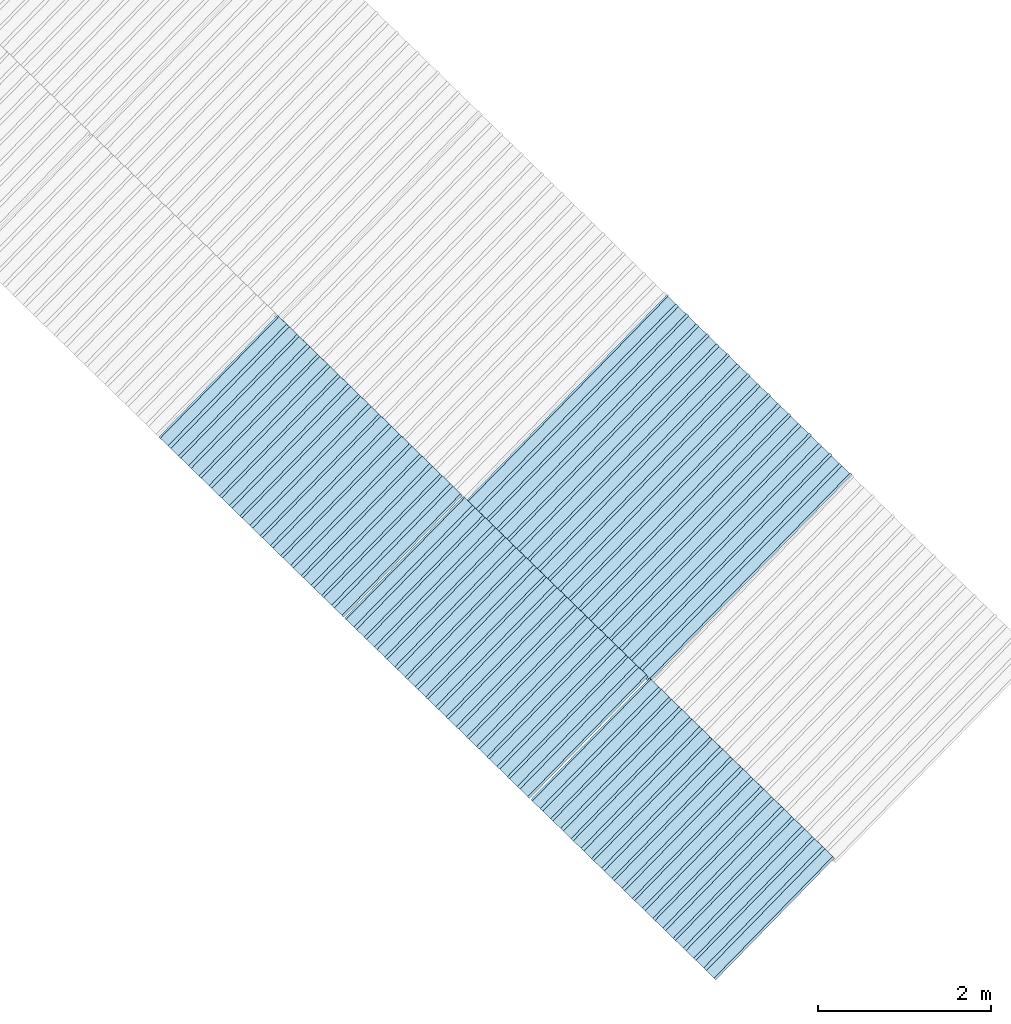
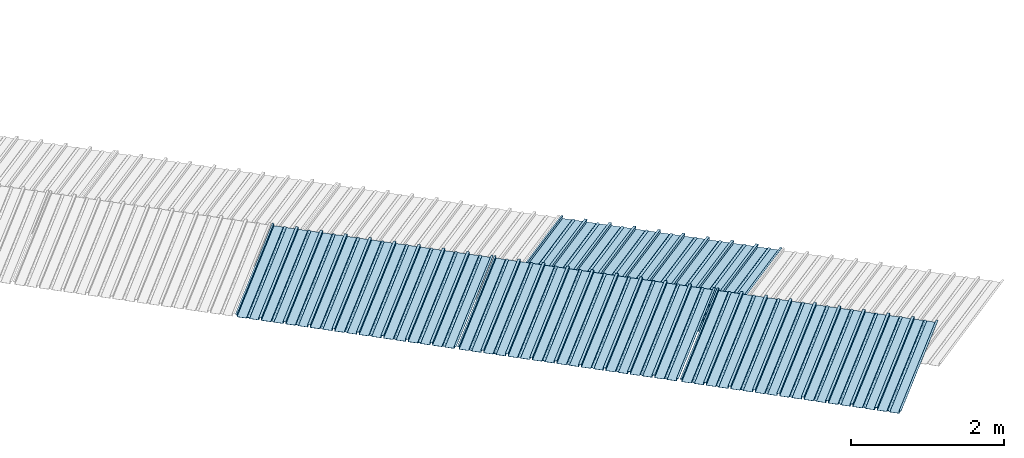
# One storey, part 3 of 8: 4 plates, 2 elements without a shape of their own.
"""IFC4 building model written with IfcOpenShell, lengths in metres."""

from ifc_helpers import new_model, entity, si_unit, converted_unit, direction, frame, origin, place, context, subcontext, project, spatial, line, arc, indexed_curve, outline, extrude, source, transform, mapped, material, type_object, type_shapes, element, aggregate, save


model = new_model("IFC4")

# Units and contexts
model_context = context("Model", 3, precision=1e-05, world=origin(), true_north=direction((6.123233995736766e-17, 1.0)))
body_context = subcontext(model_context, "Body", "Model", "MODEL_VIEW")
ifc_project = project(units=[si_unit("LENGTHUNIT", "METRE"), si_unit("AREAUNIT", "SQUARE_METRE"), si_unit("VOLUMEUNIT", "CUBIC_METRE"), converted_unit("PLANEANGLEUNIT", "DEGREE", entity("IfcPlaneAngleMeasure", 0.017453292519943278), si_unit("PLANEANGLEUNIT", "RADIAN"), dimensions=[0, 0, 0, 0, 0, 0, 0])], contexts=[model_context])

# Site, building, storey
site_placement = place(None, frame((0.0, 0.0, 0.0), z_axis=(0.0, 0.0, 1.0), x_axis=(0.7160934825303189, -0.6980043870045516, 0.0)))
site = spatial("IfcSite", under=ifc_project, at=site_placement, CompositionType="ELEMENT")
building_placement = place(site_placement, origin())
building = spatial("IfcBuilding", under=site, at=building_placement, CompositionType="ELEMENT")
storey_placement = place(building_placement, frame((0.0, 0.0, -1.24)))
storey = spatial("IfcBuildingStorey", under=building, at=storey_placement, Name="Livello 5", CompositionType="ELEMENT", Elevation=-1.24)

# Roof, plates
curtain_wall_type = type_object("IfcCurtainWallType", Name="Vetrata Copertura 2", PredefinedType="NOTDEFINED")
roof_1_placement = place(storey_placement, frame((0.0, 0.0, 1.24)))
roof_1 = element("IfcRoof", 1, at=roof_1_placement, inside=storey, type_object=curtain_wall_type, Name="Vetrata Copertura 2", ObjectType="Vetrata Copertura 2", PredefinedType="SHED_ROOF")
ifc_material = material(Name="Default")
plate_type_1 = type_object("IfcPlateType", Name="Pannello copertura:Pannello copertura", PredefinedType="CURTAIN_PANEL", material=ifc_material)
shared_shape_1 = source(origin(), body_context, "Body", "SweptSolid", [
    extrude(outline(indexed_curve([(1.339910560042256, -0.015785714285718594), (1.4699105600422562, -0.015785714285719003), (1.4699105600422562, 0.024214285714281004), (1.494919197675959, 0.02421428571428092), (1.494919197675959, 0.027214285714280917), (1.466910560042256, 0.027214285714281014), (1.466910560042256, -0.012785714285718995), (1.3417510978483753, -0.012785714285718492), (1.3199105600422556, 4.9134324369942785e-05), (1.2980700222361363, -0.012785714285718328), (1.1729105600422558, -0.01278571428571804), (1.1729105600422558, 0.02721428571428197), (1.136910560042256, 0.027214285714282097), (1.136910560042256, -0.012785714285717937), (1.0117510978483748, -0.01278571428571754), (0.9899105600422554, 4.913432437100935e-05), (0.968070022236136, -0.01278571428571726), (0.8429105600422558, -0.012785714285716971), (0.842910560042256, 0.027214285714283023), (0.8069105600422554, 0.027214285714283144), (0.8069105600422554, -0.01278571428571687), (0.6817510978483748, -0.012785714285716475), (0.6599105600422555, 4.9134324372075926e-05), (0.6380700222361361, -0.012785714285716196), (0.5129105600422553, -0.012785714285715915), (0.5129105600422554, 0.027214285714284105), (0.47691056004225557, 0.027214285714284227), (0.47691056004225557, -0.012785714285715804), (0.3517510978483749, -0.012785714285715427), (0.32991056004225544, 4.9134324373142496e-05), (0.3080700222361361, -0.012785714285715127), (0.18291056004225528, -0.012785714285714848), (0.18291056004225553, 0.027214285714285157), (0.1469105600422553, 0.02721428571428528), (0.14691056004225533, -0.012785714285714738), (0.021751097848374697, -0.01278571428571434), (-8.943995774469983e-05, 4.913432437420907e-05), (-0.021929977763864118, -0.01278571428571406), (-0.1470894399577447, -0.012785714285713783), (-0.14708943995774473, 0.02721428571428624), (-0.18308943995774493, 0.027214285714286364), (-0.1830894399577449, -0.012785714285713672), (-0.30824890215162537, -0.012785714285713215), (-0.33008943995774487, 4.9134324375275644e-05), (-0.3519299777638641, -0.012785714285712995), (-0.47708943995774494, -0.012785714285712714), (-0.4770894399577447, 0.02721428571428729), (-0.5130894399577449, 0.02721428571428741), (-0.5130894399577449, -0.012785714285712603), (-0.6382489021516256, -0.012785714285712207), (-0.6600894399577448, 4.9134324376342214e-05), (-0.6819299777638644, -0.012785714285711926), (-0.8070894399577453, -0.012785714285711647), (-0.807089439957745, 0.027214285714288373), (-0.843089439957745, 0.027214285714288494), (-0.8430894399577447, -0.012785714285711538), (-0.968248902151626, -0.012785714285711083), (-0.9900894399577453, 4.9134324377408785e-05), (-1.0119299777638646, -0.012785714285710861), (-1.1370894399577456, -0.012785714285710582), (-1.1370894399577451, 0.02721428571428942), (-1.1730894399577452, 0.027214285714289545), (-1.1730894399577454, -0.012785714285710473), (-1.2982489021516257, -0.012785714285710093), (-1.3200894399577452, 4.9134324378475355e-05), (-1.3419299777638647, -0.012785714285709794), (-1.4670894399577457, -0.012785714285709513), (-1.4670894399577454, 0.027214285714290503), (-1.490089439957745, 0.027214285714290586), (-1.490089439957745, 0.024214285714290556), (-1.4700894399577447, 0.02421428571429049), (-1.4700894399577449, -0.015785714285709514), (-1.3400894399577452, -0.015785714285709924), (-1.3200894399577452, -0.0029508656756215236), (-1.3000894399577452, -0.015785714285710063), (-1.170089439957745, -0.015785714285710472), (-1.1700894399577453, 0.024214285714289543), (-1.140089439957745, 0.02421428571428944), (-1.1400894399577455, -0.015785714285710583), (-1.0100894399577454, -0.015785714285710992), (-0.9900894399577453, -0.00295086567562259), (-0.9700894399577453, -0.015785714285711128), (-0.8400894399577448, -0.01578571428571154), (-0.8400894399577451, 0.024214285714288453), (-0.8100894399577452, 0.024214285714288356), (-0.8100894399577452, -0.015785714285711648), (-0.6800894399577451, -0.015785714285712012), (-0.6600894399577448, -0.0029508656756236573), (-0.6400894399577448, -0.015785714285712196), (-0.5100894399577451, -0.015785714285712606), (-0.5100894399577451, 0.024214285714287406), (-0.4800894399577449, 0.024214285714287305), (-0.4800894399577449, -0.015785714285712713), (-0.350089439957745, -0.01578571428571316), (-0.33008943995774487, -0.0029508656756247237), (-0.31008943995774485, -0.01578571428571326), (-0.1800894399577448, -0.015785714285713674), (-0.1800894399577448, 0.024214285714286323), (-0.1500894399577446, 0.02421428571428622), (-0.15008943995774485, -0.015785714285713782), (-0.020089439957744877, -0.015785714285714264), (-8.943995774473269e-05, -0.00295086567562579), (0.01991056004225521, -0.015785714285714323), (0.14991056004225545, -0.01578571428571474), (0.14991056004225542, 0.024214285714285272), (0.17991056004225567, 0.02421428571428517), (0.1799105600422554, -0.01578571428571485), (0.30991056004225526, -0.01578571428571532), (0.32991056004225544, -0.0029508656756268565), (0.3499105600422554, -0.015785714285715395), (0.47991056004225535, -0.015785714285715804), (0.47991056004225535, 0.02421428571428419), (0.5099105600422553, 0.02421428571428409), (0.5099105600422552, -0.015785714285715916), (0.6399105600422554, -0.015785714285716325), (0.6599105600422555, -0.002950865675627923), (0.6799105600422555, -0.01578571428571646), (0.8099105600422557, -0.015785714285716873), (0.8099105600422557, 0.02421428571428314), (0.8399105600422555, 0.02421428571428304), (0.8399105600422554, -0.015785714285716974), (0.9699105600422554, -0.015785714285717393), (0.9899105600422554, -0.0029508656756289894), (1.0099105600422555, -0.01578571428571753), (1.1399105600422557, -0.015785714285717938), (1.1399105600422557, 0.024214285714282077), (1.169910560042256, 0.024214285714281972), (1.1699105600422557, -0.01578571428571804), (1.2999105600422558, -0.01578571428571846), (1.3199105600422558, -0.0029508656756300567)], segments=[line(1, 2, 3, 4, 5, 6, 7, 8), arc(8, 9, 10), line(10, 11, 12, 13, 14, 15), arc(15, 16, 17), line(17, 18, 19, 20, 21, 22), arc(22, 23, 24), line(24, 25, 26, 27, 28, 29), arc(29, 30, 31), line(31, 32, 33, 34, 35, 36), arc(36, 37, 38), line(38, 39, 40, 41, 42, 43), arc(43, 44, 45), line(45, 46, 47, 48, 49, 50), arc(50, 51, 52), line(52, 53, 54, 55, 56, 57), arc(57, 58, 59), line(59, 60, 61, 62, 63, 64), arc(64, 65, 66), line(66, 67, 68, 69, 70, 71, 72, 73), arc(73, 74, 75), line(75, 76, 77, 78, 79, 80), arc(80, 81, 82), line(82, 83, 84, 85, 86, 87), arc(87, 88, 89), line(89, 90, 91, 92, 93, 94), arc(94, 95, 96), line(96, 97, 98, 99, 100, 101), arc(101, 102, 103), line(103, 104, 105, 106, 107, 108), arc(108, 109, 110), line(110, 111, 112, 113, 114, 115), arc(115, 116, 117), line(117, 118, 119, 120, 121, 122), arc(122, 123, 124), line(124, 125, 126, 127, 128, 129), arc(129, 130, 1)], self_intersect=False)), frame((8.080232403624576e-05, -0.015785714285719014, 0.0), z_axis=(0.0, 0.0, -1.0), x_axis=(1.0, 0.0, 0.0)), (0.0, 0.0, -1.0), 1.9691142879617602),
])
type_shapes(plate_type_1, [shared_shape_1])
plate_1_placement = place(roof_1_placement, frame((0.7679036127094641, -6.922854376535778, -1.0800000000000003), z_axis=(0.0, 0.9980594686585702, 0.0622679453729828), x_axis=(1.0, 0.0, 0.0)))
plate_1 = element("IfcPlate", 2, at=plate_1_placement, type_object=plate_type_1, material=ifc_material, Name="Pannello copertura:Pannello copertura", ObjectType="Pannello copertura:Pannello copertura", PredefinedType="CURTAIN_PANEL", context=body_context, shape_type="MappedRepresentation", body=[
    mapped(shared_shape_1, transform((0.0, 0.0, 0.0), scale=1.0)),
])
plate_2_placement = place(roof_1_placement, frame((3.7679082367906167, -6.922854376535778, -1.0800000000000003), z_axis=(0.0, 0.9980594686585702, 0.0622679453729828), x_axis=(1.0, 0.0, 0.0)))
plate_2 = element("IfcPlate", 3, at=plate_2_placement, type_object=plate_type_1, material=ifc_material, Name="Pannello copertura:Pannello copertura", ObjectType="Pannello copertura:Pannello copertura", PredefinedType="CURTAIN_PANEL", context=body_context, shape_type="MappedRepresentation", body=[
    mapped(shared_shape_1, transform((0.0, 0.0, 0.0), scale=1.0)),
])
plate_type_2 = type_object("IfcPlateType", Name="Pannello copertura:Pannello copertura", PredefinedType="CURTAIN_PANEL", material=ifc_material)
shared_shape_2 = source(origin(), body_context, "Body", "SweptSolid", [
    extrude(outline(indexed_curve([(1.339910560042256, -0.015785714285718594), (1.4699105600422562, -0.015785714285719003), (1.4699105600422562, 0.024214285714281004), (1.494919197675959, 0.02421428571428092), (1.494919197675959, 0.027214285714280917), (1.466910560042256, 0.027214285714281014), (1.466910560042256, -0.012785714285718995), (1.3417510978483753, -0.012785714285718492), (1.3199105600422556, 4.9134324369942785e-05), (1.2980700222361363, -0.012785714285718328), (1.1729105600422558, -0.01278571428571804), (1.1729105600422558, 0.02721428571428197), (1.136910560042256, 0.027214285714282097), (1.136910560042256, -0.012785714285717937), (1.0117510978483748, -0.01278571428571754), (0.9899105600422554, 4.913432437100935e-05), (0.968070022236136, -0.01278571428571726), (0.8429105600422558, -0.012785714285716971), (0.842910560042256, 0.027214285714283023), (0.8069105600422554, 0.027214285714283144), (0.8069105600422554, -0.01278571428571687), (0.6817510978483748, -0.012785714285716475), (0.6599105600422555, 4.9134324372075926e-05), (0.6380700222361361, -0.012785714285716196), (0.5129105600422553, -0.012785714285715915), (0.5129105600422554, 0.027214285714284105), (0.47691056004225557, 0.027214285714284227), (0.47691056004225557, -0.012785714285715804), (0.3517510978483749, -0.012785714285715427), (0.32991056004225544, 4.9134324373142496e-05), (0.3080700222361361, -0.012785714285715127), (0.18291056004225528, -0.012785714285714848), (0.18291056004225553, 0.027214285714285157), (0.1469105600422553, 0.02721428571428528), (0.14691056004225533, -0.012785714285714738), (0.021751097848374697, -0.01278571428571434), (-8.943995774469983e-05, 4.913432437420907e-05), (-0.021929977763864118, -0.01278571428571406), (-0.1470894399577447, -0.012785714285713783), (-0.14708943995774473, 0.02721428571428624), (-0.18308943995774493, 0.027214285714286364), (-0.1830894399577449, -0.012785714285713672), (-0.30824890215162537, -0.012785714285713215), (-0.33008943995774487, 4.9134324375275644e-05), (-0.3519299777638641, -0.012785714285712995), (-0.47708943995774494, -0.012785714285712714), (-0.4770894399577447, 0.02721428571428729), (-0.5130894399577449, 0.02721428571428741), (-0.5130894399577449, -0.012785714285712603), (-0.6382489021516256, -0.012785714285712207), (-0.6600894399577448, 4.9134324376342214e-05), (-0.6819299777638644, -0.012785714285711926), (-0.8070894399577453, -0.012785714285711647), (-0.807089439957745, 0.027214285714288373), (-0.843089439957745, 0.027214285714288494), (-0.8430894399577447, -0.012785714285711538), (-0.968248902151626, -0.012785714285711083), (-0.9900894399577453, 4.9134324377408785e-05), (-1.0119299777638646, -0.012785714285710861), (-1.1370894399577456, -0.012785714285710582), (-1.1370894399577451, 0.02721428571428942), (-1.1730894399577452, 0.027214285714289545), (-1.1730894399577454, -0.012785714285710473), (-1.2982489021516257, -0.012785714285710093), (-1.3200894399577452, 4.9134324378475355e-05), (-1.3419299777638647, -0.012785714285709794), (-1.4670894399577457, -0.012785714285709513), (-1.4670894399577454, 0.027214285714290503), (-1.490089439957745, 0.027214285714290586), (-1.490089439957745, 0.024214285714290556), (-1.4700894399577447, 0.02421428571429049), (-1.4700894399577449, -0.015785714285709514), (-1.3400894399577452, -0.015785714285709924), (-1.3200894399577452, -0.0029508656756215236), (-1.3000894399577452, -0.015785714285710063), (-1.170089439957745, -0.015785714285710472), (-1.1700894399577453, 0.024214285714289543), (-1.140089439957745, 0.02421428571428944), (-1.1400894399577455, -0.015785714285710583), (-1.0100894399577454, -0.015785714285710992), (-0.9900894399577453, -0.00295086567562259), (-0.9700894399577453, -0.015785714285711128), (-0.8400894399577448, -0.01578571428571154), (-0.8400894399577451, 0.024214285714288453), (-0.8100894399577452, 0.024214285714288356), (-0.8100894399577452, -0.015785714285711648), (-0.6800894399577451, -0.015785714285712012), (-0.6600894399577448, -0.0029508656756236573), (-0.6400894399577448, -0.015785714285712196), (-0.5100894399577451, -0.015785714285712606), (-0.5100894399577451, 0.024214285714287406), (-0.4800894399577449, 0.024214285714287305), (-0.4800894399577449, -0.015785714285712713), (-0.350089439957745, -0.01578571428571316), (-0.33008943995774487, -0.0029508656756247237), (-0.31008943995774485, -0.01578571428571326), (-0.1800894399577448, -0.015785714285713674), (-0.1800894399577448, 0.024214285714286323), (-0.1500894399577446, 0.02421428571428622), (-0.15008943995774485, -0.015785714285713782), (-0.020089439957744877, -0.015785714285714264), (-8.943995774473269e-05, -0.00295086567562579), (0.01991056004225521, -0.015785714285714323), (0.14991056004225545, -0.01578571428571474), (0.14991056004225542, 0.024214285714285272), (0.17991056004225567, 0.02421428571428517), (0.1799105600422554, -0.01578571428571485), (0.30991056004225526, -0.01578571428571532), (0.32991056004225544, -0.0029508656756268565), (0.3499105600422554, -0.015785714285715395), (0.47991056004225535, -0.015785714285715804), (0.47991056004225535, 0.02421428571428419), (0.5099105600422553, 0.02421428571428409), (0.5099105600422552, -0.015785714285715916), (0.6399105600422554, -0.015785714285716325), (0.6599105600422555, -0.002950865675627923), (0.6799105600422555, -0.01578571428571646), (0.8099105600422557, -0.015785714285716873), (0.8099105600422557, 0.02421428571428314), (0.8399105600422555, 0.02421428571428304), (0.8399105600422554, -0.015785714285716974), (0.9699105600422554, -0.015785714285717393), (0.9899105600422554, -0.0029508656756289894), (1.0099105600422555, -0.01578571428571753), (1.1399105600422557, -0.015785714285717938), (1.1399105600422557, 0.024214285714282077), (1.169910560042256, 0.024214285714281972), (1.1699105600422557, -0.01578571428571804), (1.2999105600422558, -0.01578571428571846), (1.3199105600422558, -0.0029508656756300567)], segments=[line(1, 2, 3, 4, 5, 6, 7, 8), arc(8, 9, 10), line(10, 11, 12, 13, 14, 15), arc(15, 16, 17), line(17, 18, 19, 20, 21, 22), arc(22, 23, 24), line(24, 25, 26, 27, 28, 29), arc(29, 30, 31), line(31, 32, 33, 34, 35, 36), arc(36, 37, 38), line(38, 39, 40, 41, 42, 43), arc(43, 44, 45), line(45, 46, 47, 48, 49, 50), arc(50, 51, 52), line(52, 53, 54, 55, 56, 57), arc(57, 58, 59), line(59, 60, 61, 62, 63, 64), arc(64, 65, 66), line(66, 67, 68, 69, 70, 71, 72, 73), arc(73, 74, 75), line(75, 76, 77, 78, 79, 80), arc(80, 81, 82), line(82, 83, 84, 85, 86, 87), arc(87, 88, 89), line(89, 90, 91, 92, 93, 94), arc(94, 95, 96), line(96, 97, 98, 99, 100, 101), arc(101, 102, 103), line(103, 104, 105, 106, 107, 108), arc(108, 109, 110), line(110, 111, 112, 113, 114, 115), arc(115, 116, 117), line(117, 118, 119, 120, 121, 122), arc(122, 123, 124), line(124, 125, 126, 127, 128, 129), arc(129, 130, 1)], self_intersect=False)), frame((8.080232403624576e-05, -0.015785714285719014, 0.0), z_axis=(0.0, 0.0, -1.0), x_axis=(1.0, 0.0, 0.0)), (0.0, 0.0, -1.0), 1.9691142879617602),
])
type_shapes(plate_type_2, [shared_shape_2])
plate_3_placement = place(roof_1_placement, frame((6.7749376868462985, -6.9228543765357795, -1.0800000000000003), z_axis=(0.0, 0.9980594686585702, 0.0622679453729828), x_axis=(1.0, 0.0, 0.0)))
plate_3 = element("IfcPlate", 4, at=plate_3_placement, type_object=plate_type_2, material=ifc_material, Name="Pannello copertura:Pannello copertura", ObjectType="Pannello copertura:Pannello copertura", PredefinedType="CURTAIN_PANEL", context=body_context, shape_type="MappedRepresentation", body=[
    mapped(shared_shape_2, transform((0.0, 0.0, 0.0), scale=1.0)),
])
aggregate(roof_1, [plate_1, plate_2, plate_3])

# Roof, plate
roof_2_placement = place(storey_placement, frame((0.0, 0.0, 1.24)))
roof_2 = element("IfcRoof", 5, at=roof_2_placement, inside=storey, type_object=curtain_wall_type, Name="Vetrata Copertura 2", ObjectType="Vetrata Copertura 2", PredefinedType="SHED_ROOF")
plate_type_3 = type_object("IfcPlateType", Name="Pannello copertura:Pannello copertura", PredefinedType="CURTAIN_PANEL", material=ifc_material)
shared_shape_3 = source(origin(), body_context, "Body", "SweptSolid", [
    extrude(outline(indexed_curve([(1.339910560042256, -0.015785714285718594), (1.4699105600422562, -0.015785714285719003), (1.4699105600422562, 0.024214285714281004), (1.494919197675959, 0.02421428571428092), (1.494919197675959, 0.027214285714280917), (1.466910560042256, 0.027214285714281014), (1.466910560042256, -0.012785714285718995), (1.3417510978483753, -0.012785714285718492), (1.3199105600422556, 4.9134324369942785e-05), (1.2980700222361363, -0.012785714285718328), (1.1729105600422558, -0.01278571428571804), (1.1729105600422558, 0.02721428571428197), (1.136910560042256, 0.027214285714282097), (1.136910560042256, -0.012785714285717937), (1.0117510978483748, -0.01278571428571754), (0.9899105600422554, 4.913432437100935e-05), (0.968070022236136, -0.01278571428571726), (0.8429105600422558, -0.012785714285716971), (0.842910560042256, 0.027214285714283023), (0.8069105600422554, 0.027214285714283144), (0.8069105600422554, -0.01278571428571687), (0.6817510978483748, -0.012785714285716475), (0.6599105600422555, 4.9134324372075926e-05), (0.6380700222361361, -0.012785714285716196), (0.5129105600422553, -0.012785714285715915), (0.5129105600422554, 0.027214285714284105), (0.47691056004225557, 0.027214285714284227), (0.47691056004225557, -0.012785714285715804), (0.3517510978483749, -0.012785714285715427), (0.32991056004225544, 4.9134324373142496e-05), (0.3080700222361361, -0.012785714285715127), (0.18291056004225528, -0.012785714285714848), (0.18291056004225553, 0.027214285714285157), (0.1469105600422553, 0.02721428571428528), (0.14691056004225533, -0.012785714285714738), (0.021751097848374697, -0.01278571428571434), (-8.943995774469983e-05, 4.913432437420907e-05), (-0.021929977763864118, -0.01278571428571406), (-0.1470894399577447, -0.012785714285713783), (-0.14708943995774473, 0.02721428571428624), (-0.18308943995774493, 0.027214285714286364), (-0.1830894399577449, -0.012785714285713672), (-0.30824890215162537, -0.012785714285713215), (-0.33008943995774487, 4.9134324375275644e-05), (-0.3519299777638641, -0.012785714285712995), (-0.47708943995774494, -0.012785714285712714), (-0.4770894399577447, 0.02721428571428729), (-0.5130894399577449, 0.02721428571428741), (-0.5130894399577449, -0.012785714285712603), (-0.6382489021516256, -0.012785714285712207), (-0.6600894399577448, 4.9134324376342214e-05), (-0.6819299777638644, -0.012785714285711926), (-0.8070894399577453, -0.012785714285711647), (-0.807089439957745, 0.027214285714288373), (-0.843089439957745, 0.027214285714288494), (-0.8430894399577447, -0.012785714285711538), (-0.968248902151626, -0.012785714285711083), (-0.9900894399577453, 4.9134324377408785e-05), (-1.0119299777638646, -0.012785714285710861), (-1.1370894399577456, -0.012785714285710582), (-1.1370894399577451, 0.02721428571428942), (-1.1730894399577452, 0.027214285714289545), (-1.1730894399577454, -0.012785714285710473), (-1.2982489021516257, -0.012785714285710093), (-1.3200894399577452, 4.9134324378475355e-05), (-1.3419299777638647, -0.012785714285709794), (-1.4670894399577457, -0.012785714285709513), (-1.4670894399577454, 0.027214285714290503), (-1.490089439957745, 0.027214285714290586), (-1.490089439957745, 0.024214285714290556), (-1.4700894399577447, 0.02421428571429049), (-1.4700894399577449, -0.015785714285709514), (-1.3400894399577452, -0.015785714285709924), (-1.3200894399577452, -0.0029508656756215236), (-1.3000894399577452, -0.015785714285710063), (-1.170089439957745, -0.015785714285710472), (-1.1700894399577453, 0.024214285714289543), (-1.140089439957745, 0.02421428571428944), (-1.1400894399577455, -0.015785714285710583), (-1.0100894399577454, -0.015785714285710992), (-0.9900894399577453, -0.00295086567562259), (-0.9700894399577453, -0.015785714285711128), (-0.8400894399577448, -0.01578571428571154), (-0.8400894399577451, 0.024214285714288453), (-0.8100894399577452, 0.024214285714288356), (-0.8100894399577452, -0.015785714285711648), (-0.6800894399577451, -0.015785714285712012), (-0.6600894399577448, -0.0029508656756236573), (-0.6400894399577448, -0.015785714285712196), (-0.5100894399577451, -0.015785714285712606), (-0.5100894399577451, 0.024214285714287406), (-0.4800894399577449, 0.024214285714287305), (-0.4800894399577449, -0.015785714285712713), (-0.350089439957745, -0.01578571428571316), (-0.33008943995774487, -0.0029508656756247237), (-0.31008943995774485, -0.01578571428571326), (-0.1800894399577448, -0.015785714285713674), (-0.1800894399577448, 0.024214285714286323), (-0.1500894399577446, 0.02421428571428622), (-0.15008943995774485, -0.015785714285713782), (-0.020089439957744877, -0.015785714285714264), (-8.943995774473269e-05, -0.00295086567562579), (0.01991056004225521, -0.015785714285714323), (0.14991056004225545, -0.01578571428571474), (0.14991056004225542, 0.024214285714285272), (0.17991056004225567, 0.02421428571428517), (0.1799105600422554, -0.01578571428571485), (0.30991056004225526, -0.01578571428571532), (0.32991056004225544, -0.0029508656756268565), (0.3499105600422554, -0.015785714285715395), (0.47991056004225535, -0.015785714285715804), (0.47991056004225535, 0.02421428571428419), (0.5099105600422553, 0.02421428571428409), (0.5099105600422552, -0.015785714285715916), (0.6399105600422554, -0.015785714285716325), (0.6599105600422555, -0.002950865675627923), (0.6799105600422555, -0.01578571428571646), (0.8099105600422557, -0.015785714285716873), (0.8099105600422557, 0.02421428571428314), (0.8399105600422555, 0.02421428571428304), (0.8399105600422554, -0.015785714285716974), (0.9699105600422554, -0.015785714285717393), (0.9899105600422554, -0.0029508656756289894), (1.0099105600422555, -0.01578571428571753), (1.1399105600422557, -0.015785714285717938), (1.1399105600422557, 0.024214285714282077), (1.169910560042256, 0.024214285714281972), (1.1699105600422557, -0.01578571428571804), (1.2999105600422558, -0.01578571428571846), (1.3199105600422558, -0.0029508656756300567)], segments=[line(1, 2, 3, 4, 5, 6, 7, 8), arc(8, 9, 10), line(10, 11, 12, 13, 14, 15), arc(15, 16, 17), line(17, 18, 19, 20, 21, 22), arc(22, 23, 24), line(24, 25, 26, 27, 28, 29), arc(29, 30, 31), line(31, 32, 33, 34, 35, 36), arc(36, 37, 38), line(38, 39, 40, 41, 42, 43), arc(43, 44, 45), line(45, 46, 47, 48, 49, 50), arc(50, 51, 52), line(52, 53, 54, 55, 56, 57), arc(57, 58, 59), line(59, 60, 61, 62, 63, 64), arc(64, 65, 66), line(66, 67, 68, 69, 70, 71, 72, 73), arc(73, 74, 75), line(75, 76, 77, 78, 79, 80), arc(80, 81, 82), line(82, 83, 84, 85, 86, 87), arc(87, 88, 89), line(89, 90, 91, 92, 93, 94), arc(94, 95, 96), line(96, 97, 98, 99, 100, 101), arc(101, 102, 103), line(103, 104, 105, 106, 107, 108), arc(108, 109, 110), line(110, 111, 112, 113, 114, 115), arc(115, 116, 117), line(117, 118, 119, 120, 121, 122), arc(122, 123, 124), line(124, 125, 126, 127, 128, 129), arc(129, 130, 1)], self_intersect=False)), frame((8.080232403624576e-05, -0.015785714285719014, 0.0), z_axis=(0.0, 0.0, -1.0), x_axis=(1.0, 0.0, 0.0)), (0.0, 0.0, -1.0), 3.472878469300717),
])
type_shapes(plate_type_3, [shared_shape_3])
plate_4_placement = place(roof_2_placement, frame((3.8251665245433415, -4.997561216564662, -1.6240000000000003), z_axis=(0.0, 0.9632563788424056, -0.26858359707810914), x_axis=(1.0, 0.0, 0.0)))
plate_4 = element("IfcPlate", 6, at=plate_4_placement, type_object=plate_type_3, material=ifc_material, Name="Pannello copertura:Pannello copertura", ObjectType="Pannello copertura:Pannello copertura", PredefinedType="CURTAIN_PANEL", context=body_context, shape_type="MappedRepresentation", body=[
    mapped(shared_shape_3, transform((0.0, 0.0, 0.0), scale=1.0)),
])
aggregate(roof_2, [plate_4])

save(model, "model.ifc")
